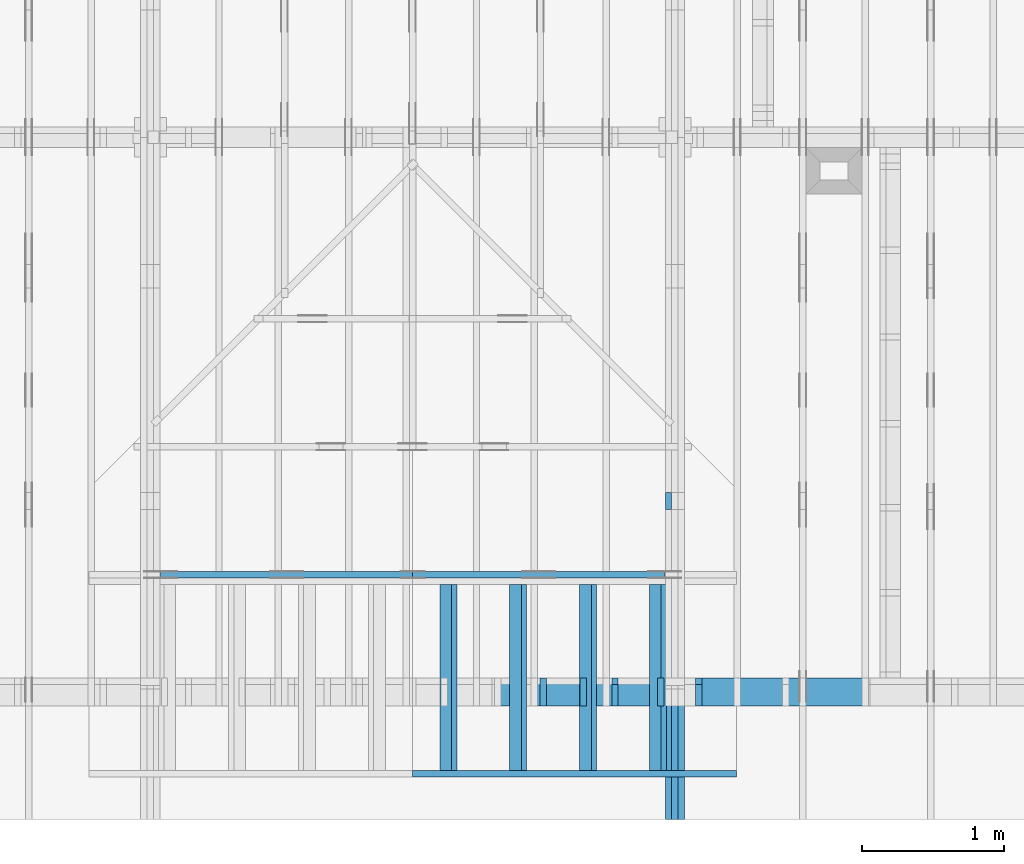
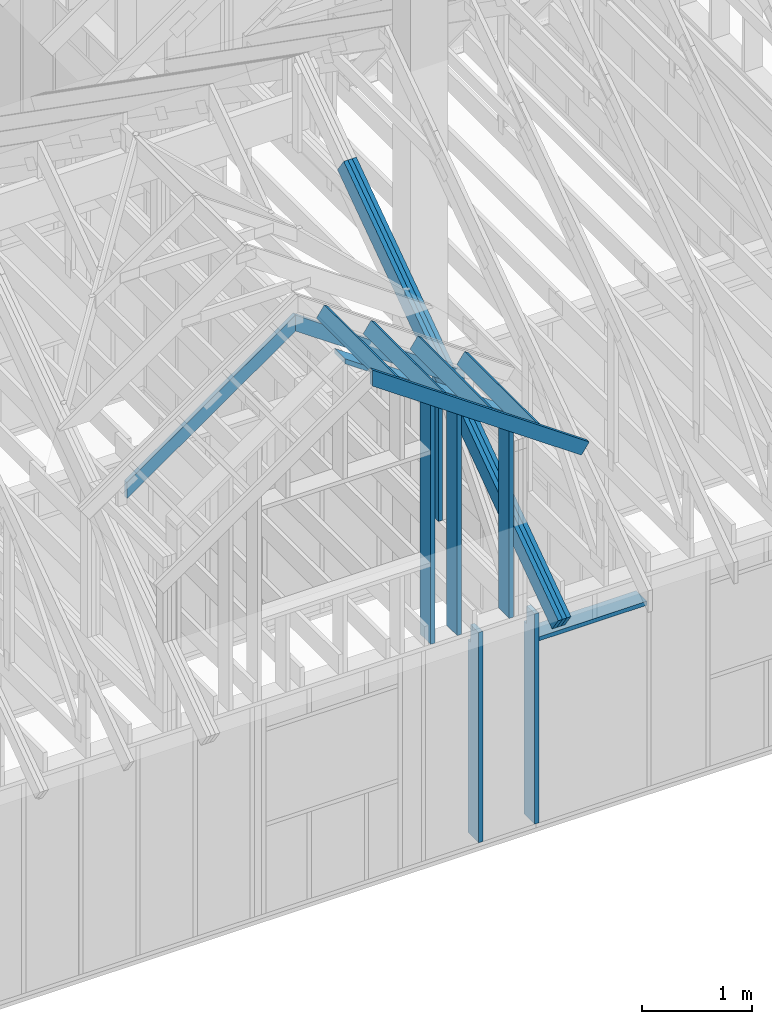
# One storey, part 7 of 70: 18 members, 5 elements without a shape of their own.
"""IFC2X3 building model written with IfcOpenShell, lengths in millimetres."""

from ifc_helpers import new_model, si_unit, frame, origin, origin_with_axes, origin_2d, place, context, project, spatial, faceted_brep, element, aggregate, save


model = new_model("IFC2X3")

# Units and contexts
model_context = context("Model", 3, precision=1e-05, world=origin())
plan_context = context("Plan", 2, precision=1e-05, world=origin_2d())
ifc_project = project(units=[si_unit("LENGTHUNIT", "METRE", prefix="MILLI"), si_unit("AREAUNIT", "SQUARE_METRE"), si_unit("VOLUMEUNIT", "CUBIC_METRE"), si_unit("SOLIDANGLEUNIT", "STERADIAN"), si_unit("PLANEANGLEUNIT", "RADIAN"), si_unit("MASSUNIT", "GRAM"), si_unit("TIMEUNIT", "SECOND"), si_unit("THERMODYNAMICTEMPERATUREUNIT", "DEGREE_CELSIUS"), si_unit("LUMINOUSINTENSITYUNIT", "LUMEN")], contexts=[model_context, plan_context])

# Site, building, storey
site_placement = place(None, origin_with_axes())
site = spatial("IfcSite", under=ifc_project, at=site_placement, CompositionType="ELEMENT")
building_placement = place(site_placement, origin_with_axes())
building = spatial("IfcBuilding", under=site, at=building_placement, Name="Layout 1", CompositionType="ELEMENT")
storey_placement = place(building_placement, origin_with_axes())
storey = spatial("IfcBuildingStorey", under=building, at=storey_placement, Name="Storey 1", CompositionType="ELEMENT", Elevation=0.0)

# Assembly, members
assembly_1_placement = place(storey_placement, frame((5660.000000000293, 8000.0, 9.122500660690286e-13), z_axis=(-1.0, 1.836909530733566e-16, 6.123031769111886e-17), x_axis=(-1.836909530733566e-16, -1.0, 0.0)))
assembly_1 = element("IfcElementAssembly", 1, at=assembly_1_placement, inside=storey, Name="T11", AssemblyPlace="FACTORY", PredefinedType="TRUSS")
member_1_placement = place(assembly_1_placement, frame((4782.309641268, 3014.9999999994516, -90.00000000000001), z_axis=(0.0, 0.0, 1.0), x_axis=(0.8191520442889916, -0.5735764363510465, 0.0)))
member_1 = element("IfcMember", 2, at=member_1_placement, Name="T9", context=model_context, shape_type="Brep", body=[
    faceted_brep([(4768.153825500908, 195.00000000180353, 45.0), (1.6370904631912708e-10, 195.00000000180353, 45.0), (0.0, 1.8071659724228084e-09, 45.0), (4768.153825500287, 1.8071659724228084e-09, 45.0), (1.6370904631912708e-10, 195.00000000180353, 2.004791383006049e-26), (4768.153825500908, 195.00000000180353, 5.839111470710887e-13), (4768.153825500287, 1.8071659724228084e-09, 5.839111470710126e-13), (0.0, 1.8071659724228084e-09, 0.0), (-1.2523674699591298e-25, 1.8071659724228084e-09, 7.668285805162028e-42), (2.755364295975112e-15, 1.8071659724228084e-09, 45.0), (1.636957134777711e-10, 195.000000001015, 45.0), (1.63692958113475e-10, 195.000000001015, 9.850859431565386e-31), (4768.153825500287, -2.042652045517506e-12, 1.250722336794479e-28), (4768.153825500287, -2.039896681221406e-12, 45.0), (1.0454840658689129e-27, 1.8071687277871045e-09, 45.0), (0.0, 1.8071659724228084e-09, 0.0), (4768.153825500287, 195.00000000180353, -3.8067271842345146e-26), (4768.153825500287, 195.00000000180353, 45.0), (4768.153825500287, 0.0, 45.0), (4768.153825500287, 0.0, 0.0), (1.6370904631912708e-10, 195.000000001015, 0.0), (1.6370904631912708e-10, 195.000000001015, 45.0), (4768.153825500908, 195.00000000180347, 45.0), (4768.153825500908, 195.00000000180347, -4.733165431326071e-30)], [[[0, 1, 2, 3]], [[4, 5, 6, 7]], [[8, 9, 10, 11]], [[12, 13, 14, 15]], [[16, 17, 18, 19]], [[20, 21, 22, 23]]]),
])
member_2_placement = place(assembly_1_placement, frame((4782.309641268, 3014.9999999994516, -135.0), z_axis=(0.0, 0.0, 1.0), x_axis=(0.8191520442889916, -0.5735764363510465, 0.0)))
member_2 = element("IfcMember", 3, at=member_2_placement, Name="T9", context=model_context, shape_type="Brep", body=[
    faceted_brep([(4768.153825500908, 195.00000000180353, 45.0), (1.6370904631912708e-10, 195.00000000180353, 45.0), (0.0, 1.8071659724228084e-09, 45.0), (4768.153825500287, 1.8071659724228084e-09, 45.0), (1.6370904631912708e-10, 195.00000000180353, 2.004791383006049e-26), (4768.153825500908, 195.00000000180353, 5.839111470710887e-13), (4768.153825500287, 1.8071659724228084e-09, 5.839111470710126e-13), (0.0, 1.8071659724228084e-09, 0.0), (-1.2523674699591298e-25, 1.8071659724228084e-09, 7.668285805162028e-42), (2.755364295975112e-15, 1.8071659724228084e-09, 45.0), (1.636957134777711e-10, 195.000000001015, 45.0), (1.63692958113475e-10, 195.000000001015, 9.850859431565386e-31), (4768.153825500287, -2.042652045517506e-12, 1.250722336794479e-28), (4768.153825500287, -2.039896681221406e-12, 45.0), (1.0454840658689129e-27, 1.8071687277871045e-09, 45.0), (0.0, 1.8071659724228084e-09, 0.0), (4768.153825500287, 195.00000000180353, -3.8067271842345146e-26), (4768.153825500287, 195.00000000180353, 45.0), (4768.153825500287, 0.0, 45.0), (4768.153825500287, 0.0, 0.0), (1.6370904631912708e-10, 195.000000001015, 0.0), (1.6370904631912708e-10, 195.000000001015, 45.0), (4768.153825500908, 195.00000000180347, 45.0), (4768.153825500908, 195.00000000180347, -4.733165431326071e-30)], [[[0, 1, 2, 3]], [[4, 5, 6, 7]], [[8, 9, 10, 11]], [[12, 13, 14, 15]], [[16, 17, 18, 19]], [[20, 21, 22, 23]]]),
])
member_3_placement = place(assembly_1_placement, frame((4782.309641268, 3014.9999999994516, -180.00000000000003), z_axis=(0.0, 0.0, 1.0), x_axis=(0.8191520442889916, -0.5735764363510465, 0.0)))
member_3 = element("IfcMember", 4, at=member_3_placement, Name="T9", context=model_context, shape_type="Brep", body=[
    faceted_brep([(4768.153825500908, 195.00000000180353, 45.0), (1.6370904631912708e-10, 195.00000000180353, 45.0), (0.0, 1.8071659724228084e-09, 45.0), (4768.153825500287, 1.8071659724228084e-09, 45.0), (1.6370904631912708e-10, 195.00000000180353, 2.004791383006049e-26), (4768.153825500908, 195.00000000180353, 5.839111470710887e-13), (4768.153825500287, 1.8071659724228084e-09, 5.839111470710126e-13), (0.0, 1.8071659724228084e-09, 0.0), (-1.2523674699591298e-25, 1.8071659724228084e-09, 7.668285805162028e-42), (2.755364295975112e-15, 1.8071659724228084e-09, 45.0), (1.636957134777711e-10, 195.000000001015, 45.0), (1.63692958113475e-10, 195.000000001015, 9.850859431565386e-31), (4768.153825500287, -2.042652045517506e-12, 1.250722336794479e-28), (4768.153825500287, -2.039896681221406e-12, 45.0), (1.0454840658689129e-27, 1.8071687277871045e-09, 45.0), (0.0, 1.8071659724228084e-09, 0.0), (4768.153825500287, 195.00000000180353, -3.8067271842345146e-26), (4768.153825500287, 195.00000000180353, 45.0), (4768.153825500287, 0.0, 45.0), (4768.153825500287, 0.0, 0.0), (1.6370904631912708e-10, 195.000000001015, 0.0), (1.6370904631912708e-10, 195.000000001015, 45.0), (4768.153825500908, 195.00000000180347, 45.0), (4768.153825500908, 195.00000000180347, -4.733165431326071e-30)], [[[0, 1, 2, 3]], [[4, 5, 6, 7]], [[8, 9, 10, 11]], [[12, 13, 14, 15]], [[16, 17, 18, 19]], [[20, 21, 22, 23]]]),
])
member_4_placement = place(assembly_1_placement, frame((6619.9999999949505, 219.99999999999994, -90.0), z_axis=(0.0, 0.0, 1.0), x_axis=(5.053195275411815e-16, 1.0, 0.0)))
member_4 = element("IfcMember", 5, at=member_4_placement, Name="R1", context=model_context, shape_type="Brep", body=[
    faceted_brep([(1592.2602625099316, 120.00000000000091, 45.0), (0.0, 120.00000000000091, 45.0), (5.684341886080802e-14, 0.0, 45.0), (1508.2353579246992, 0.0, 45.0), (0.0, 120.00000000000091, 0.0), (1592.2602625099316, 120.00000000000091, 1.9498920344085486e-13), (1508.2353579246992, 0.0, 1.846994602374154e-13), (5.684341886080802e-14, 0.0, 6.961081190993225e-30), (5.684341886080802e-14, 0.0, 0.0), (5.959878315690836e-14, 8.86203890694297e-31, 45.0), (2.1003354220769377e-14, 120.0, 45.0), (1.8247989924669028e-14, 120.0, -1.1173302203118208e-30), (1508.2353579246992, -2.7704919035612314e-13, 7.265245946951848e-29), (1508.2353579246992, -2.742938260600228e-13, 45.0), (5.684341886080802e-14, 2.7553642961003043e-15, 45.0), (5.684341886080802e-14, -4.4719288075722504e-29, 2.7381762157971524e-45), (1592.260262509932, 120.00000000000057, 1.9009198412843567e-29), (1592.260262509932, 120.00000000000057, 45.0), (1508.2353579246997, 6.821210263296962e-13, 45.0), (1508.2353579246997, 6.821210263296962e-13, 3.2533805409343593e-29), (0.0, 120.0, 0.0), (0.0, 120.0, 45.0), (1592.2602625099316, 120.00000000000131, 45.0), (1592.2602625099316, 120.00000000000132, 2.524354896707238e-29)], [[[0, 1, 2, 3]], [[4, 5, 6, 7]], [[8, 9, 10, 11]], [[12, 13, 14, 15]], [[16, 17, 18, 19]], [[20, 21, 22, 23]]]),
])
aggregate(assembly_1, [member_1, member_2, member_3, member_4])

assembly_2_placement = place(storey_placement, frame((6205.00000000017, 945.0, 1.3776821480501744e-15), z_axis=(1.2246063538223773e-16, 1.0, 6.123031769111886e-17), x_axis=(-1.0, 1.2246063538223773e-16, 0.0)))
assembly_2 = element("IfcElementAssembly", 6, at=assembly_2_placement, inside=storey, Name="T7", AssemblyPlace="FACTORY", PredefinedType="TRUSS")
member_5_placement = place(assembly_2_placement, frame((504.9999999997294, 2008.4376775114215, -45.00000000000001), z_axis=(0.0, 0.0, 1.0), x_axis=(0.8191520442888068, 0.5735764363513103, 0.0)))
member_5 = element("IfcMember", 7, at=member_5_placement, Name="SC4", context=model_context, shape_type="Brep", body=[
    faceted_brep([(2265.353051621194, 144.99999999997908, 45.0), (101.53009303993463, 144.99999999997908, 45.0), (0.0, 0.0, 45.0), (2163.8229585808813, 0.0, 45.0), (101.53009303993463, 144.99999999997908, 1.2433439704088107e-14), (2265.353051621194, 144.99999999997908, 2.774165740666226e-13), (2163.8229585808813, 0.0, 2.649831343624882e-13), (0.0, 0.0, 0.0), (-1.1640850691069998e-14, 8.151011405021721e-15, 8.701351488741532e-31), (-9.383788395154928e-15, 6.5705993712206755e-15, 45.0), (101.5300930399346, 145.0000000000214, 45.0), (101.5300930399346, 145.0000000000214, 3.2367178645371886e-30), (2163.8229585808813, 2.571318799841273e-10, 7.130976599384513e-29), (2163.8229585808813, 2.571346353484234e-10, 45.0), (-3.274260487383315e-28, 2.755364296100349e-15, 45.0), (0.0, 0.0, 0.0), (2265.3530516211936, 144.9999999999793, -2.524354896707238e-29), (2265.3530516211936, 144.9999999999793, 45.0), (2163.8229585808813, 2.588649294921197e-10, 45.0), (2163.8229585808813, 2.588649294921197e-10, -2.524354896707238e-29), (101.53009303993463, 145.00000000002137, 1.5777218104420236e-30), (101.53009303993463, 145.00000000002137, 45.0), (2265.353051621194, 144.99999999997897, 45.0), (2265.353051621194, 144.99999999997897, -6.310887241768095e-30)], [[[0, 1, 2, 3]], [[4, 5, 6, 7]], [[8, 9, 10, 11]], [[12, 13, 14, 15]], [[16, 17, 18, 19]], [[20, 21, 22, 23]]]),
])
member_6_placement = place(assembly_2_placement, frame((4133.168583271578, 2127.2147239330807, -45.0), z_axis=(0.0, 0.0, 1.0), x_axis=(-0.8191520442887644, 0.5735764363513708, 0.0)))
member_6 = element("IfcMember", 8, at=member_6_placement, Name="SC4", context=model_context, shape_type="Brep", body=[
    faceted_brep([(2163.8229585820964, 144.99999999822012, 45.0), (0.0, 144.99999999822012, 45.0), (101.53009303880299, 1.0913936421275139e-11, 45.0), (2265.3530516213305, 1.0913936421275139e-11, 45.0), (0.0, 144.99999999822012, 0.0), (2163.8229585820964, 144.99999999822012, 2.64983134362637e-13), (2265.3530516213305, 1.0913936421275139e-11, 2.774165740666393e-13), (101.53009303880299, 1.0913936421275139e-11, 1.2433439703949525e-14), (101.53009303880302, 1.0928147275990341e-11, -1.9366243649520926e-30), (101.53009303880302, 1.0928147275990341e-11, 45.0), (-2.842170943040401e-14, 145.00000000000728, 45.0), (-2.842170943040401e-14, 145.00000000000728, 2.3097418757572767e-30), (2265.3530516213305, 9.497227431558483e-13, -5.815182528191349e-29), (2265.3530516213305, 9.524781074519487e-13, 45.0), (101.53009303880299, 1.0959257088319377e-11, 45.0), (101.53009303880299, 1.0956501724023277e-11, -2.606287009887168e-30), (2163.8229585820964, 144.99999999822012, 0.0), (2163.8229585820964, 144.99999999822012, 45.0), (2265.3530516213305, 0.0, 45.0), (2265.3530516213305, 0.0, 0.0), (0.0, 145.00000000000728, 0.0), (0.0, 145.00000000000728, 45.0), (2163.8229585820964, 144.99999999822077, 45.0), (2163.8229585820964, 144.99999999822077, 3.944304526105059e-29)], [[[0, 1, 2, 3]], [[4, 5, 6, 7]], [[8, 9, 10, 11]], [[12, 13, 14, 15]], [[16, 17, 18, 19]], [[20, 21, 22, 23]]]),
])
aggregate(assembly_2, [member_5, member_6])

assembly_3_placement = place(storey_placement, frame((-48.55339059325575, 0.0, -2470.0), z_axis=(0.0, -1.0, 6.123031769111886e-17), x_axis=(1.0, 0.0, 0.0)))
assembly_3 = element("IfcElementAssembly", 9, at=assembly_3_placement, inside=storey, Name="VE4", AssemblyPlace="FACTORY", PredefinedType="NOTDEFINED")
member_7_placement = place(assembly_3_placement, frame((5377.499999992957, 2425.0, -195.00000000000003), z_axis=(0.0, 0.0, 1.0), x_axis=(7.044874666267686e-16, -1.0, 0.0)))
member_7 = element("IfcMember", 10, at=member_7_placement, Name="S11", context=model_context, shape_type="Brep", body=[
    faceted_brep([(0.0, 45.00000000001455, 45.00000000000003), (195.00000000186265, 45.00000000001455, 45.00000000000005), (195.00000000186265, 0.0, 45.00000000000005), (0.0, 0.0, 45.00000000000003), (195.00000000186265, 9.094947017729282e-13, 2.842170943040401e-14), (195.00000000186265, 9.094947017729282e-13, 45.00000000000003), (195.00000000186265, 45.00000000001455, 45.00000000000003), (195.00000000186265, 45.00000000001455, 2.842170943040401e-14), (2.7553642961003504e-15, -3.3742366240998114e-31, 45.00000000000003), (1.1939911949768181e-14, -1.4621692037765844e-30, 195.00000000000006), (1.7450640541970662e-14, 45.00000000001455, 195.00000000000006), (8.26609288830283e-15, 45.00000000001455, 45.00000000000003), (2335.0, -4.2891837542628763e-13, 2.842170943040403e-14), (2335.0, -4.1697846347651946e-13, 195.00000000000003), (2.1932538056648764e-30, 1.193991194976818e-14, 195.00000000000003), (5.061354936149717e-31, 2.7553642961003504e-15, 45.00000000000003), (195.00000000186265, -3.306437155354634e-14, 45.00000000000003), (195.00000000186265, -3.5819735849646686e-14, 2.842170943040401e-14), (-1.6871183120499057e-31, 45.00000000001455, 45.00000000000003), (-7.310846018882921e-31, 45.00000000001454, 195.00000000000003), (2335.0, 45.000000000014396, 195.00000000000003), (2335.0, 45.00000000001441, 2.8421709430403998e-14), (195.00000000186265, 45.00000000001454, 2.8421709430404004e-14), (195.00000000186265, 45.00000000001454, 45.00000000000003), (2335.0, 45.00000000001273, 0.0), (2335.0, 45.00000000001273, 195.00000000000003), (2335.0, 1.2732925824820995e-11, 195.00000000000003), (2335.0, 1.2732925824820995e-11, 0.0), (2335.0, 45.00000000001273, 195.00000000000003), (0.0, 45.00000000001273, 195.00000000000003), (0.0, 0.0, 195.00000000000003), (2335.0, 0.0, 195.00000000000003), (195.00000000186265, 45.00000000001455, 5.2301533330168465e-14), (2335.0, 45.00000000001455, 3.143672930479291e-13), (2335.0, 1.2732925824820995e-11, 3.143672930479291e-13), (195.00000000186265, 1.2732925824820995e-11, 5.2301533330168465e-14)], [[[0, 1, 2, 3]], [[4, 5, 6, 7]], [[8, 9, 10, 11]], [[12, 13, 14, 15, 16, 17]], [[18, 19, 20, 21, 22, 23]], [[24, 25, 26, 27]], [[28, 29, 30, 31]], [[32, 33, 34, 35]]]),
])
member_8_placement = place(assembly_3_placement, frame((5967.49999999479, 2425.0, -195.00000000000003), z_axis=(0.0, 0.0, 1.0), x_axis=(-1.836909530733566e-16, -1.0, 0.0)))
member_8 = element("IfcMember", 11, at=member_8_placement, Name="S11", context=model_context, shape_type="Brep", body=[
    faceted_brep([(0.0, 45.0, 45.00000000000003), (195.00000000186265, 45.0, 45.00000000000005), (195.00000000186265, 0.0, 45.00000000000005), (0.0, 0.0, 45.00000000000003), (195.00000000186265, -2.1311460639909362e-46, 2.842170943040401e-14), (195.00000000186265, -3.3742366240998114e-31, 45.00000000000003), (195.00000000186265, 45.0, 45.00000000000003), (195.00000000186265, 45.0, 2.842170943040401e-14), (2.7553642961003504e-15, -3.3742366240998114e-31, 45.00000000000003), (1.193991194976818e-14, -1.4621692037765842e-30, 195.00000000000003), (1.7450640541968876e-14, 45.0, 195.00000000000003), (8.266092888301048e-15, 45.0, 45.00000000000003), (2335.0, -4.2891837542628763e-13, 2.842170943040403e-14), (2335.0, -4.1697846347651946e-13, 195.00000000000003), (2.1932538056648764e-30, 1.193991194976818e-14, 195.00000000000003), (5.061354936149717e-31, 2.7553642961003504e-15, 45.00000000000003), (195.00000000186265, -3.306437155354634e-14, 45.00000000000003), (195.00000000186265, -3.5819735849646686e-14, 2.842170943040401e-14), (-1.6871183120499057e-31, 45.0, 45.00000000000003), (-7.310846018882921e-31, 44.999999999999986, 195.00000000000003), (2335.0, 44.999999999999844, 195.00000000000003), (2335.0, 44.99999999999986, 2.8421709430403998e-14), (195.00000000186265, 44.999999999999986, 2.842170943040401e-14), (195.00000000186265, 44.999999999999986, 45.00000000000003), (2335.0, 45.0, 0.0), (2335.0, 45.0, 195.00000000000003), (2335.0, 0.0, 195.00000000000003), (2335.0, 0.0, 0.0), (2335.0, 45.0, 195.00000000000003), (0.0, 45.0, 195.00000000000003), (0.0, 0.0, 195.00000000000003), (2335.0, 0.0, 195.00000000000003), (195.00000000186265, 45.0, 5.2301533330168465e-14), (2335.0, 45.0, 3.143672930479291e-13), (2335.0, 0.0, 3.143672930479291e-13), (195.00000000186265, 0.0, 5.2301533330168465e-14)], [[[0, 1, 2, 3]], [[4, 5, 6, 7]], [[8, 9, 10, 11]], [[12, 13, 14, 15, 16, 17]], [[18, 19, 20, 21, 22, 23]], [[24, 25, 26, 27]], [[28, 29, 30, 31]], [[32, 33, 34, 35]]]),
])
member_9_placement = place(assembly_3_placement, frame((7147.303390593403, 2154.9999999987776, -195.0), z_axis=(0.0, 0.0, 1.0), x_axis=(-1.0, 1.2246063538223773e-16, 0.0)))
member_9 = element("IfcMember", 12, at=member_9_placement, Name="S28", context=model_context, shape_type="Brep", body=[
    faceted_brep([(1134.8033906004457, 45.00000000001455, 195.0), (0.0, 45.00000000001455, 195.0), (0.0, 0.0, 195.0), (1134.8033906004457, 0.0, 195.0), (0.0, 45.00000000001455, 0.0), (1134.8033906004457, 45.00000000001455, 1.3896874424684827e-13), (1134.8033906004457, 0.0, 1.3896874424684827e-13), (0.0, 0.0, 0.0), (0.0, 0.0, 0.0), (1.1939911949768178e-14, -1.462169203776584e-30, 195.0), (1.745064054197066e-14, 45.00000000001455, 195.0), (5.51072859220248e-15, 45.00000000001455, -3.3742366241009005e-31), (1134.8033906004457, -2.0845311637027243e-13, 1.276365053905555e-29), (1134.8033906004457, -1.9651320442050425e-13, 195.0), (2.193253805664876e-30, 1.1939911949768178e-14, 195.0), (0.0, 0.0, 0.0), (1134.8033906004457, 45.00000000001455, 0.0), (1134.8033906004457, 45.00000000001455, 195.0), (1134.8033906004457, 0.0, 195.0), (1134.8033906004457, 0.0, 0.0), (-1.2154326714572542e-63, 45.00000000001455, 0.0), (-7.31084601888292e-31, 45.00000000001454, 195.0), (1134.8033906004457, 45.000000000014474, 195.0), (1134.8033906004457, 45.00000000001448, -4.338734978715565e-30)], [[[0, 1, 2, 3]], [[4, 5, 6, 7]], [[8, 9, 10, 11]], [[12, 13, 14, 15]], [[16, 17, 18, 19]], [[20, 21, 22, 23]]]),
])
aggregate(assembly_3, [member_7, member_8, member_9])

assembly_4_placement = place(storey_placement, frame((5705.000000000031, 195.0, 0.0), z_axis=(1.2246063538223773e-16, 1.0, 6.123031769111886e-17), x_axis=(-1.0, 1.2246063538223773e-16, 0.0)))
assembly_4 = element("IfcElementAssembly", 13, at=assembly_4_placement, inside=storey, Name="VEg2", AssemblyPlace="FACTORY", PredefinedType="NOTDEFINED")
member_10_placement = place(assembly_4_placement, frame((9.999999999740112, 2195.054903516546, -195.0), z_axis=(0.0, 0.0, 1.0), x_axis=(0.8191520442889916, 0.5735764363510464, 0.0)))
member_10 = element("IfcMember", 14, at=member_10_placement, Name="P10", context=model_context, shape_type="Brep", body=[
    faceted_brep([(2189.2284248566, 45.0000000013315, 195.0), (31.509339219794356, 45.0000000013315, 195.0), (0.0, 0.0, 195.0), (2157.7190856368056, 0.0, 195.0), (31.509339219794356, 45.0000000013315, 3.858653701330479e-15), (2189.2284248566, 45.0000000013315, 2.680943039047947e-13), (2157.7190856368056, 0.0, 2.642356502034642e-13), (0.0, 0.0, 0.0), (0.0, 0.0, 0.0), (9.780603282283166e-15, -6.848452146493301e-15, 195.0), (31.509339219794363, 45.000000000510454, 195.0), (31.509339219794352, 45.00000000051046, 1.9721522630525295e-31), (2157.7190856368056, 8.217562038812669e-10, -5.738722932672884e-29), (2157.7190856368056, 8.217681437932166e-10, 195.0), (-4.54725398863604e-27, 1.1939911949768178e-14, 195.0), (0.0, 0.0, 0.0), (2189.2284248566007, 45.00000000133139, 3.7865323450608567e-29), (2189.2284248566007, 45.00000000133139, 195.0), (2157.719085636806, 8.204779078369029e-10, 195.0), (2157.719085636806, 8.204779078369029e-10, 3.7865323450608567e-29), (31.509339219794356, 45.000000000510454, 3.944304526105059e-31), (31.509339219794356, 45.00000000051045, 195.0), (2189.2284248566, 45.00000000133151, 195.0), (2189.2284248566, 45.00000000133152, 1.5777218104420236e-30)], [[[0, 1, 2, 3]], [[4, 5, 6, 7]], [[8, 9, 10, 11]], [[12, 13, 14, 15]], [[16, 17, 18, 19]], [[20, 21, 22, 23]]]),
])
member_11_placement = place(assembly_4_placement, frame((55.0, -1.6966219011302353e-14, -195.0), z_axis=(0.0, 0.0, 1.0), x_axis=(6.123031769111886e-17, 1.0, 0.0)))
member_11 = element("IfcMember", 15, at=member_11_placement, Name="S15", context=model_context, shape_type="Brep", body=[
    faceted_brep([(2195.054903517477, 45.000000000000135, 195.0), (0.0, 45.000000000000135, 195.0), (2.755364296100349e-15, 0.0, 195.0), (2226.5642427364364, 0.0, 195.0), (0.0, 45.000000000000135, 0.0), (2195.054903517477, 45.000000000000135, 2.688078181836468e-13), (2226.5642427364364, 0.0, 2.72666471884875e-13), (2.755364296100349e-15, 0.0, 3.3742366240998092e-31), (2.755364296100349e-15, 0.0, 0.0), (1.4695276245868527e-14, -1.462169203776584e-30, 195.0), (2.0206004838069225e-14, 45.0, 195.0), (8.266092888301046e-15, 45.0, -5.061354936149714e-31), (2226.5642427364364, 9.310341525256406e-10, 2.5926460104217924e-29), (2226.5642427364364, 9.310460924375904e-10, 195.0), (2.755364296095356e-15, 1.1939911949768177e-14, 195.0), (2.755364296100349e-15, -5.239869940856476e-31, 3.208389011388331e-47), (2195.054903517477, 45.000000000000114, 7.532203711548534e-30), (2195.054903517477, 45.000000000000114, 195.0), (2226.5642427364364, 9.315499482909217e-10, 195.0), (2226.5642427364364, 9.315499482909217e-10, 7.870765903903491e-30), (0.0, 45.0, 0.0), (1.9721522630525295e-30, 44.999999999999986, 195.0), (2195.054903517477, 45.00000000000034, 195.0), (2195.054903517477, 45.000000000000355, 1.34106353887572e-29)], [[[0, 1, 2, 3]], [[4, 5, 6, 7]], [[8, 9, 10, 11]], [[12, 13, 14, 15]], [[16, 17, 18, 19]], [[20, 21, 22, 23]]]),
])
member_12_placement = place(assembly_4_placement, frame((555.0000000000005, 2608.1773510624116, -195.0), z_axis=(0.0, 0.0, 1.0), x_axis=(-1.836909530733566e-16, -1.0, 0.0)))
member_12 = element("IfcMember", 16, at=member_12_placement, Name="S9", context=model_context, shape_type="Brep", body=[
    faceted_brep([(2608.1773510624116, 45.0, 195.0), (0.0, 45.0, 195.0), (31.50933921946853, 2.298747858731076e-09, 195.0), (2608.1773510624116, 2.298747858731076e-09, 195.0), (0.0, 45.0, 0.0), (2608.1773510624116, 45.0, 3.1939905560066463e-13), (2608.1773510624116, 2.298747858731076e-09, 3.1939905560066463e-13), (31.50933921946853, 2.298747858731076e-09, 3.858653701290579e-15), (31.50933921946853, 2.2987460823742367e-09, 0.0), (31.509339219468536, 2.2987531878015943e-09, 195.0), (2.1316282072803006e-14, 45.00000000231331, 195.0), (1.0658141036401503e-14, 45.0000000023133, -5.9164567891575885e-31), (2608.1773510624116, 5.865476569902679e-13, -3.5914499378500945e-29), (2608.1773510624116, 5.984875689400361e-13, 195.0), (31.50933921946853, 2.2987668847137202e-09, 195.0), (31.50933921946853, 2.2987549448017705e-09, -4.338823597811223e-31), (2608.1773510624116, 45.0, 0.0), (2608.1773510624116, 45.0, 195.0), (2608.1773510624116, 0.0, 195.0), (2608.1773510624116, 0.0, 0.0), (0.0, 45.0000000023133, 0.0), (-1.2924697071141057e-26, 45.000000002313286, 195.0), (2608.1773510624116, 45.00000000000008, 195.0), (2608.1773510624116, 45.000000000000085, 5.127595883936577e-30)], [[[0, 1, 2, 3]], [[4, 5, 6, 7]], [[8, 9, 10, 11]], [[12, 13, 14, 15]], [[16, 17, 18, 19]], [[20, 21, 22, 23]]]),
])
member_13_placement = place(assembly_4_placement, frame((835.0000000000006, 2804.2354617611563, -195.0), z_axis=(0.0, 0.0, 1.0), x_axis=(-1.836909530733566e-16, -1.0, 0.0)))
member_13 = element("IfcMember", 17, at=member_13_placement, Name="P1", context=model_context, shape_type="Brep", body=[
    faceted_brep([(2804.2354617611563, 45.0, 195.0), (0.0, 45.0, 195.0), (31.509339219461253, 2.124124875990674e-09, 195.0), (2804.2354617611563, 2.124124875990674e-09, 195.0), (0.0, 45.0, 0.0), (2804.2354617611563, 45.0, 3.43408456408674e-13), (2804.2354617611563, 2.124124875990674e-09, 3.43408456408674e-13), (31.509339219461253, 2.124124875990674e-09, 3.858653701289688e-15), (31.509339219461253, 2.124124875990674e-09, -1.9721522630525295e-31), (31.509339219461268, 2.1241319814180315e-09, 195.0), (1.4210854715202004e-14, 45.00000000212402, 195.0), (3.552713678800501e-15, 45.00000000212401, -3.944304526105059e-31), (2804.2354617611563, 7.982345375228368e-13, -4.8876154324538065e-29), (2804.2354617611563, 8.10174449472605e-13, 195.0), (31.509339219461253, 2.1241457851361855e-09, 195.0), (31.509339219461253, 2.1241338452242357e-09, -5.491890204267688e-31), (2804.2354617611563, 45.0, 0.0), (2804.2354617611563, 45.0, 195.0), (2804.2354617611563, 0.0, 195.0), (2804.2354617611563, 0.0, 0.0), (0.0, 45.00000000212401, 0.0), (-6.462348535570529e-27, 45.000000002124, 195.0), (2804.2354617611563, 44.999999999999915, 195.0), (2804.2354617611563, 44.99999999999993, -4.338734978715565e-30)], [[[0, 1, 2, 3]], [[4, 5, 6, 7]], [[8, 9, 10, 11]], [[12, 13, 14, 15]], [[16, 17, 18, 19]], [[20, 21, 22, 23]]]),
])
aggregate(assembly_4, [member_10, member_11, member_12, member_13])

assembly_5_placement = place(storey_placement, frame((3927.500000000029, -499.9999999997092, 3664.618899167738), z_axis=(0.5735764363510464, -1.1073377781974438e-17, 0.8191520442889916), x_axis=(0.8191520442889916, -3.512026741791439e-17, -0.5735764363510464)))
assembly_5 = element("IfcElementAssembly", 18, at=assembly_5_placement, inside=storey, Name="gs7", AssemblyPlace="FACTORY", PredefinedType="TRUSS")
member_14_placement = place(assembly_5_placement, frame((2780.314125904361, 45.0, -145.00000000000006), z_axis=(0.0, 0.0, 1.0), x_axis=(-1.0, 1.2246063538223773e-16, 0.0)))
member_14 = element("IfcMember", 19, at=member_14_placement, Name="T6", context=model_context, shape_type="Brep", body=[
    faceted_brep([(2678.784032863514, 45.00000000000034, 3.183231456205249e-12), (2780.3141259043605, 45.00000000000034, 145.00000000000045), (2780.3141259043605, 3.410605131648481e-13, 145.00000000000023), (2678.7840328635116, 3.410605131648481e-13, 2.2737367544323206e-13), (-2.1311460639909362e-46, 45.00000000000034, 5.684341886080802e-14), (-5.43627011660525e-31, 45.000000000000334, 145.00000000000006), (2780.314125904361, 45.00000000000016, 145.00000000000006), (2678.7840328635184, 45.00000000000018, 5.6843418860808e-14), (0.0, 45.0, 5.684341886080802e-14), (2678.7840328635184, 45.0, 3.8488901357706764e-13), (2678.784032863512, 3.268496584496461e-13, 3.848890135770669e-13), (0.0, 3.268496584496461e-13, 5.684341886080802e-14), (5.220810893244919e-30, -6.393438191972809e-46, 8.526512829121202e-14), (8.878396065212238e-15, -1.08725402332105e-30, 145.00000000000006), (1.4389124657412936e-14, 44.99999999999999, 145.00000000000006), (5.5107285922007e-15, 44.99999999999999, 5.684341886080802e-14), (2780.314125904361, -1.7499049711583005e-13, 145.00000000000006), (1.630881034981575e-30, 3.357280545148583e-13, 145.00000000000006), (6.393438191972809e-46, 3.268496584496461e-13, 5.684341886080802e-14), (2678.784032863512, -1.652187336247422e-13, 5.684341886080804e-14), (2780.314125904361, 45.00000000000034, 145.00000000000006), (0.0, 45.00000000000034, 145.00000000000006), (0.0, 0.0, 145.00000000000006), (2780.314125904361, 0.0, 145.00000000000006)], [[[0, 1, 2, 3]], [[4, 5, 6, 7]], [[8, 9, 10, 11]], [[12, 13, 14, 15]], [[16, 17, 18, 19]], [[20, 21, 22, 23]]]),
])
member_15_placement = place(assembly_5_placement, frame((2135.314125906196, 1354.9999999997096, -145.0), z_axis=(0.0, 0.0, 1.0), x_axis=(-1.836909530733566e-16, -1.0, 0.0)))
member_15 = element("IfcMember", 20, at=member_15_placement, Name="W3", context=model_context, shape_type="Brep", body=[
    faceted_brep([(1309.9999999997096, 45.000000000000455, 145.0), (0.0, 45.000000000000455, 145.0), (0.0, 0.0, 145.0), (1309.9999999997096, 0.0, 145.0), (0.0, 45.000000000000455, 0.0), (1309.9999999997096, 45.000000000000455, 1.6042343235069585e-13), (1309.9999999997096, 0.0, 1.6042343235069585e-13), (0.0, 0.0, 0.0), (0.0, 0.0, 0.0), (8.878396065212235e-15, -1.0872540233210496e-30, 145.0), (1.4389124657412933e-14, 45.0, 145.0), (5.510728592200698e-15, 45.0, -3.3742366240998092e-31), (1309.9999999997096, 1.6048557068770642e-11, -6.379553059377207e-29), (1309.9999999997096, 1.6057435464835854e-11, 145.0), (-1.087675159784266e-28, 8.878396065212235e-15, 145.0), (0.0, 0.0, 0.0), (1309.9999999997096, 45.000000000000455, 0.0), (1309.9999999997096, 45.000000000000455, 145.0), (1309.9999999997096, 1.5006662579253316e-11, 145.0), (1309.9999999997096, 1.5006662579253316e-11, 0.0), (0.0, 45.0, 0.0), (3.1554436208840472e-30, 44.99999999999999, 145.0), (1309.9999999997096, 45.00000000000049, 145.0), (1309.9999999997096, 45.000000000000504, 2.7610131682735413e-30)], [[[0, 1, 2, 3]], [[4, 5, 6, 7]], [[8, 9, 10, 11]], [[12, 13, 14, 15]], [[16, 17, 18, 19]], [[20, 21, 22, 23]]]),
])
member_16_placement = place(assembly_5_placement, frame((1535.314125906196, 1354.9999999997096, -145.0), z_axis=(0.0, 0.0, 1.0), x_axis=(-1.836909530733566e-16, -1.0, 0.0)))
member_16 = element("IfcMember", 21, at=member_16_placement, Name="W3", context=model_context, shape_type="Brep", body=[
    faceted_brep([(1309.9999999997096, 45.0, 145.0), (0.0, 45.0, 145.0), (0.0, 1.432454155292362e-11, 145.0), (1309.9999999997096, 1.432454155292362e-11, 145.0), (0.0, 45.0, 0.0), (1309.9999999997096, 45.0, 1.6042343235069585e-13), (1309.9999999997096, 1.432454155292362e-11, 1.6042343235069585e-13), (0.0, 1.432454155292362e-11, 0.0), (1.7541924601302928e-27, 1.432454155292362e-11, -1.0740976162514319e-43), (8.87839606521399e-15, 1.432454155292362e-11, 145.0), (1.4389124657414687e-14, 45.000000000014325, 145.0), (5.510728592202452e-15, 45.000000000014325, -3.3742366241008834e-31), (1309.9999999997096, 1.2174164671470274e-13, -7.454279704581224e-30), (1309.9999999997096, 1.3062004277991498e-13, 145.0), (9.625807847504573e-29, 1.4333419948988832e-11, 145.0), (0.0, 1.432454155292362e-11, 0.0), (1309.9999999997096, 45.0, 0.0), (1309.9999999997096, 45.0, 145.0), (1309.9999999997096, 0.0, 145.0), (1309.9999999997096, 0.0, 0.0), (0.0, 45.000000000014325, 0.0), (-1.0097419586828951e-28, 45.00000000001432, 145.0), (1309.9999999997096, 44.999999999999986, 145.0), (1309.9999999997096, 44.99999999999999, -3.944304526105059e-31)], [[[0, 1, 2, 3]], [[4, 5, 6, 7]], [[8, 9, 10, 11]], [[12, 13, 14, 15]], [[16, 17, 18, 19]], [[20, 21, 22, 23]]]),
])
member_17_placement = place(assembly_5_placement, frame((935.3141259061958, 1354.9999999997096, -145.0), z_axis=(0.0, 0.0, 1.0), x_axis=(-1.836909530733566e-16, -1.0, 0.0)))
member_17 = element("IfcMember", 22, at=member_17_placement, Name="W3", context=model_context, shape_type="Brep", body=[
    faceted_brep([(1309.9999999997096, 45.00000000000023, 145.0), (0.0, 45.00000000000023, 145.0), (0.0, 0.0, 145.0), (1309.9999999997096, 0.0, 145.0), (0.0, 45.00000000000023, 0.0), (1309.9999999997096, 45.00000000000023, 1.6042343235069585e-13), (1309.9999999997096, 0.0, 1.6042343235069585e-13), (0.0, 0.0, 0.0), (0.0, 0.0, 0.0), (8.878396065212235e-15, -1.0872540233210496e-30, 145.0), (1.4389124657412933e-14, 45.0, 145.0), (5.510728592200698e-15, 45.0, -3.3742366240998092e-31), (1309.9999999997096, -2.406351485260438e-13, 2.865632897388569e-29), (1309.9999999997096, -2.317567524608316e-13, 145.0), (1.6308810349815745e-30, 8.878396065212235e-15, 145.0), (0.0, 0.0, 0.0), (1309.9999999997096, 45.00000000000023, 0.0), (1309.9999999997096, 45.00000000000023, 145.0), (1309.9999999997096, 2.2737367544323206e-13, 145.0), (1309.9999999997096, 2.2737367544323206e-13, 0.0), (0.0, 45.0, 0.0), (1.5777218104420236e-30, 44.99999999999999, 145.0), (1309.9999999997096, 45.0000000000002, 145.0), (1309.9999999997096, 45.00000000000021, -7.888609052210118e-31)], [[[0, 1, 2, 3]], [[4, 5, 6, 7]], [[8, 9, 10, 11]], [[12, 13, 14, 15]], [[16, 17, 18, 19]], [[20, 21, 22, 23]]]),
])
member_18_placement = place(assembly_5_placement, frame((335.31412590619584, 1354.9999999997096, -145.0), z_axis=(0.0, 0.0, 1.0), x_axis=(-1.836909530733566e-16, -1.0, 0.0)))
member_18 = element("IfcMember", 23, at=member_18_placement, Name="W3", context=model_context, shape_type="Brep", body=[
    faceted_brep([(1309.9999999997096, 45.00000000001478, 145.0), (0.0, 45.00000000001478, 145.0), (0.0, 0.0, 145.0), (1309.9999999997096, 0.0, 145.0), (0.0, 45.00000000001478, 0.0), (1309.9999999997096, 45.00000000001478, 1.6042343235069585e-13), (1309.9999999997096, 0.0, 1.6042343235069585e-13), (0.0, 0.0, 0.0), (0.0, 0.0, 0.0), (8.878396065212235e-15, -1.0872540233210496e-30, 145.0), (1.4389124657412933e-14, 45.0, 145.0), (5.510728592200698e-15, 45.0, -3.3742366240998092e-31), (1309.9999999997096, 1.6048557068770642e-11, -7.771769297575852e-29), (1309.9999999997096, 1.6057435464835854e-11, 145.0), (-1.087675159784266e-28, 8.878396065212235e-15, 145.0), (0.0, 0.0, 0.0), (1309.9999999997096, 45.00000000001478, 0.0), (1309.9999999997096, 45.00000000001478, 145.0), (1309.9999999997096, 1.4779288903810084e-11, 145.0), (1309.9999999997096, 1.4779288903810084e-11, 0.0), (0.0, 45.0, 0.0), (1.0097419586828951e-28, 44.99999999999999, 145.0), (1309.9999999997096, 45.000000000015035, 145.0), (1309.9999999997096, 45.00000000001504, 1.6566079009641248e-29)], [[[0, 1, 2, 3]], [[4, 5, 6, 7]], [[8, 9, 10, 11]], [[12, 13, 14, 15]], [[16, 17, 18, 19]], [[20, 21, 22, 23]]]),
])
aggregate(assembly_5, [member_14, member_15, member_16, member_17, member_18])

save(model, "model.ifc")
